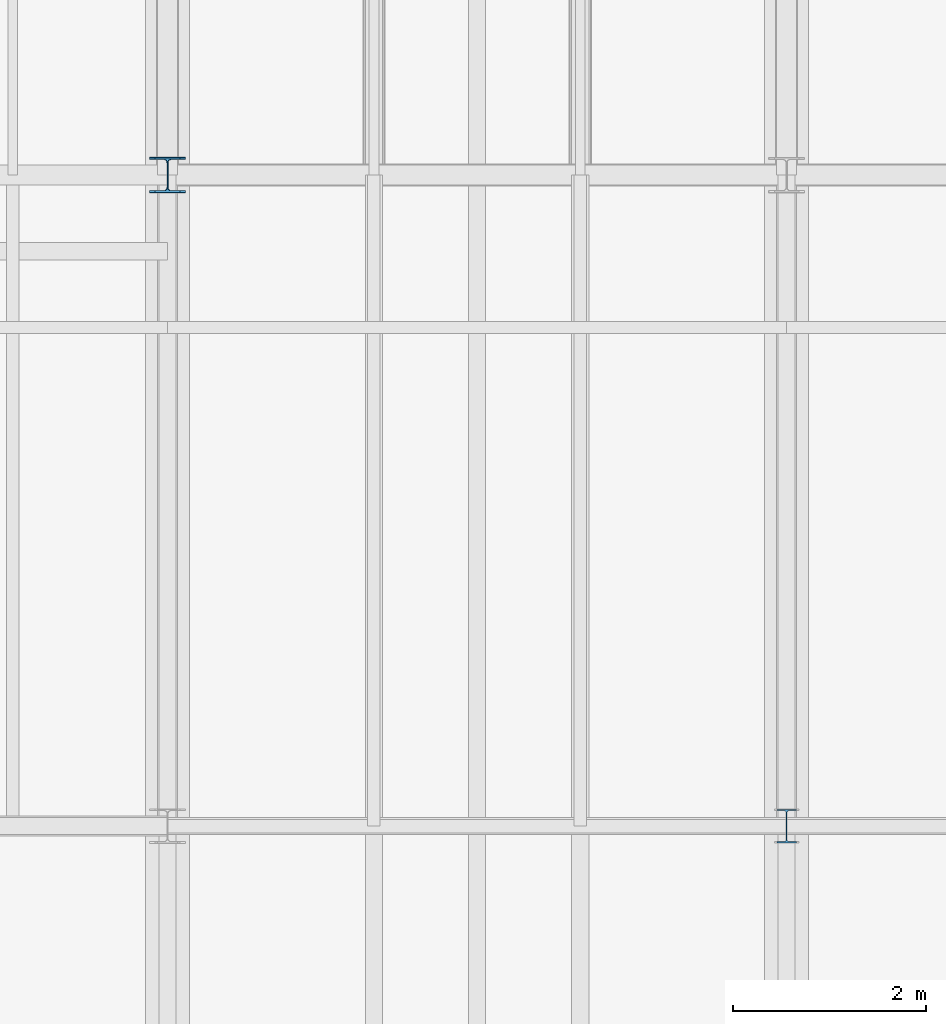
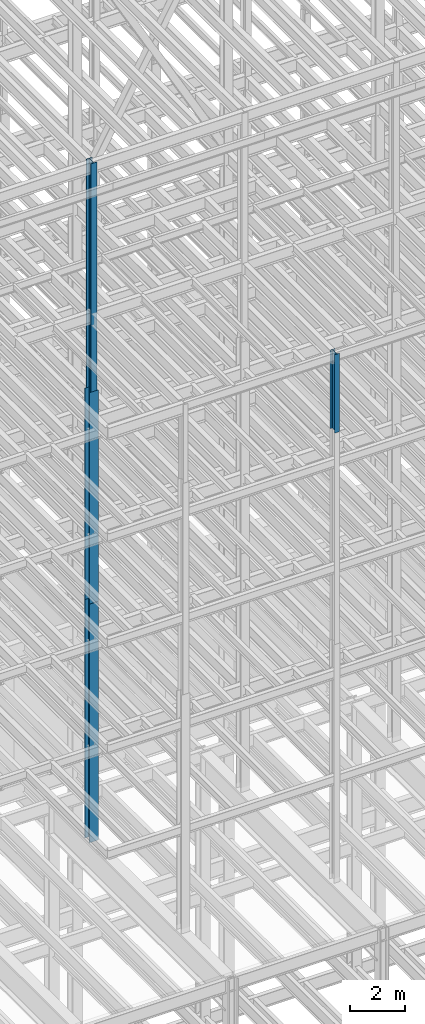
# One storey, part 6 of 150: 4 columns.
"""IFC2X3 building model written with IfcOpenShell, lengths in millimetres."""

from ifc_helpers import new_model, si_unit, frame, origin_with_axes, origin_2d_with_axis, place, context, subcontext, project, spatial, i_section, extrude, material, type_object, element, save


model = new_model("IFC2X3")

# Units and contexts
model_context = context("Model", 3, precision=1e-05, world=origin_with_axes())
body_context = subcontext(model_context, "Body", "Model", "MODEL_VIEW")
ifc_project = project(units=[si_unit("LENGTHUNIT", "METRE", prefix="MILLI"), si_unit("AREAUNIT", "SQUARE_METRE"), si_unit("VOLUMEUNIT", "CUBIC_METRE"), si_unit("MASSUNIT", "GRAM", prefix="KILO"), si_unit("TIMEUNIT", "SECOND"), si_unit("PLANEANGLEUNIT", "RADIAN"), si_unit("SOLIDANGLEUNIT", "STERADIAN"), si_unit("THERMODYNAMICTEMPERATUREUNIT", "DEGREE_CELSIUS"), si_unit("LUMINOUSINTENSITYUNIT", "LUMEN")], contexts=[model_context])

# Site, building, storey
site_placement = place(None, origin_with_axes())
site = spatial("IfcSite", under=ifc_project, at=site_placement, CompositionType="ELEMENT")
building_placement = place(site_placement, origin_with_axes())
building = spatial("IfcBuilding", under=site, at=building_placement, Name="Undefined", CompositionType="ELEMENT")
storey_placement = place(building_placement, origin_with_axes())
storey = spatial("IfcBuildingStorey", under=building, at=storey_placement, Name="Undefined", CompositionType="ELEMENT", Elevation=0.0)

# Columns
ifc_material = material(Name="STEEL/A992")
column_type_1 = type_object("IfcColumnType", Name="W14X43", PredefinedType="NOTDEFINED")
column_1_placement = place(storey_placement, frame((24587.2, 3454.39999999999, 55702.2), z_axis=(0.0, 0.0, 1.0), x_axis=(1.0, 0.0, 0.0)))
element("IfcColumn", 1, at=column_1_placement, inside=storey, type_object=column_type_1, material=ifc_material, Name="COLUMN", ObjectType="W14X43", context=body_context, shape_type="SweptSolid", body=[
    extrude(i_section(OverallWidth=203.2, OverallDepth=346.075, WebThickness=7.9375, FlangeThickness=13.462, FilletRadius=21.4629, at=origin_2d_with_axis()), frame((0.0, 0.0, 3505.20000000001), z_axis=(0.0, 0.0, -1.0), x_axis=(-1.0, 0.0, 0.0)), (0.0, 0.0, 1.0), 3505.20000000001),
])
column_type_2 = type_object("IfcColumnType", Name="W14X68", PredefinedType="NOTDEFINED")
column_2_placement = place(storey_placement, frame((18186.4, 10185.4, 55702.2), z_axis=(0.0, 0.0, 1.0), x_axis=(1.0, 0.0, 0.0)))
element("IfcColumn", 2, at=column_2_placement, inside=storey, type_object=column_type_2, material=ifc_material, Name="COLUMN", ObjectType="W14X68", context=body_context, shape_type="SweptSolid", body=[
    extrude(i_section(OverallWidth=254.0, OverallDepth=355.6, WebThickness=11.1125, FlangeThickness=18.288, FilletRadius=21.3994, at=origin_2d_with_axis()), frame((0.0, 0.0, 10210.8), z_axis=(0.0, 0.0, -1.0), x_axis=(-1.0, 0.0, 0.0)), (0.0, 0.0, 1.0), 10210.8),
])
column_type_3 = type_object("IfcColumnType", Name="W14X132", PredefinedType="NOTDEFINED")
column_3_placement = place(storey_placement, frame((18186.4, 10185.4, 35585.4), z_axis=(0.0, 0.0, 1.0), x_axis=(1.0, 0.0, 0.0)))
element("IfcColumn", 3, at=column_3_placement, inside=storey, type_object=column_type_3, material=ifc_material, Name="COLUMN", ObjectType="W14X132", context=body_context, shape_type="SweptSolid", body=[
    extrude(i_section(OverallWidth=374.65, OverallDepth=371.475, WebThickness=15.875, FlangeThickness=26.162, FilletRadius=32.5755, at=origin_2d_with_axis()), frame((0.0, 0.0, 10668.0), z_axis=(0.0, 0.0, -1.0), x_axis=(-1.0, 0.0, 0.0)), (0.0, 0.0, 1.0), 10668.0),
])
column_type_4 = type_object("IfcColumnType", Name="W14X90", PredefinedType="NOTDEFINED")
column_4_placement = place(storey_placement, frame((18186.4, 10185.4, 46253.4), z_axis=(0.0, 0.0, 1.0), x_axis=(1.0, 0.0, 0.0)))
element("IfcColumn", 4, at=column_4_placement, inside=storey, type_object=column_type_4, material=ifc_material, Name="COLUMN", ObjectType="W14X90", context=body_context, shape_type="SweptSolid", body=[
    extrude(i_section(OverallWidth=368.3, OverallDepth=355.6, WebThickness=11.1125, FlangeThickness=18.034, FilletRadius=32.7659, at=origin_2d_with_axis()), frame((0.0, 0.0, 9448.8), z_axis=(0.0, 0.0, -1.0), x_axis=(-1.0, 0.0, 0.0)), (0.0, 0.0, 1.0), 9448.8),
])

save(model, "model.ifc")
